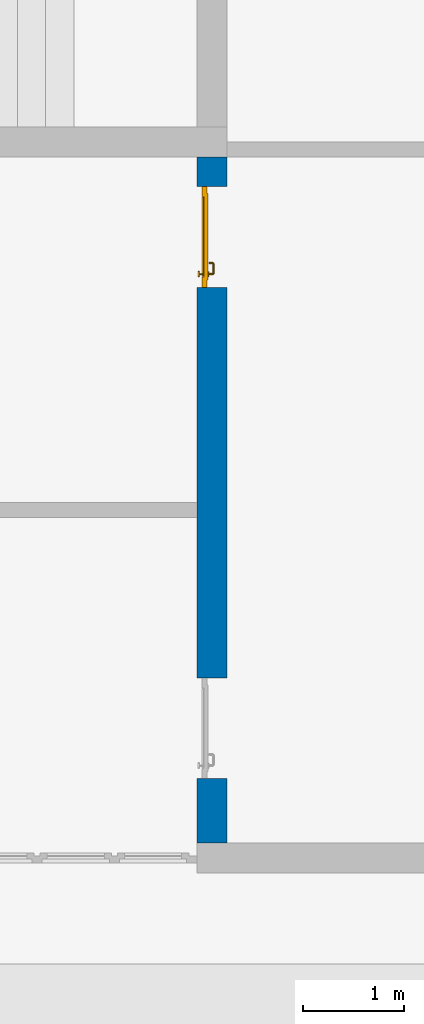
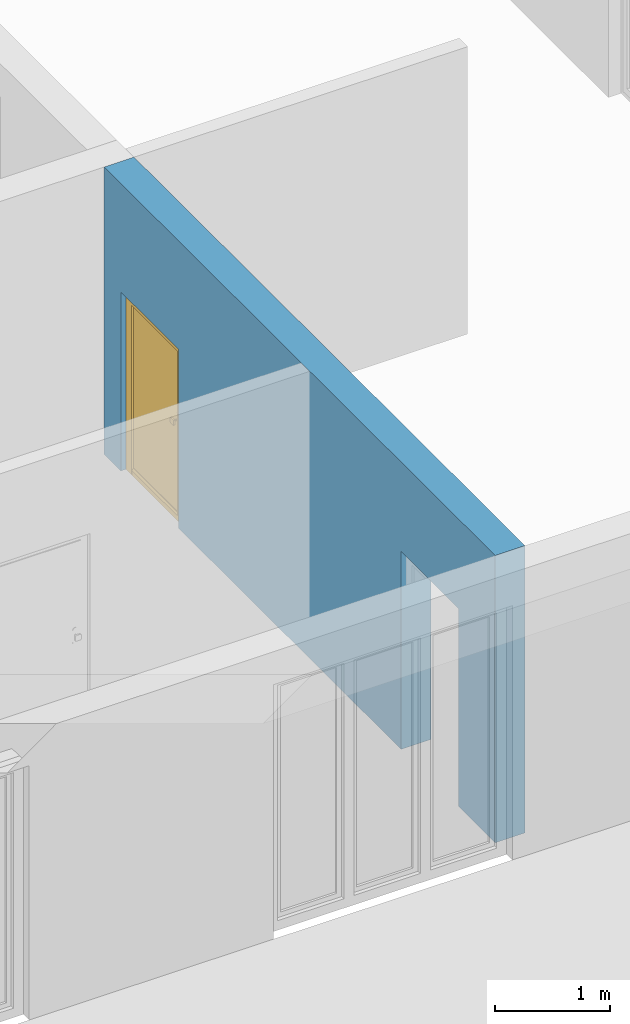
# One storey, part 7 of 23: 1 door, 1 wall, 2 openings.
"""IFC4 building model written with IfcOpenShell, lengths in metres."""

from ifc_helpers import new_model, entity, si_unit, converted_unit, derived_unit, direction, frame, origin_with_axes, place, context, subcontext, project, spatial, polygons, material, type_object, element, fill, save


model = new_model("IFC4")

# Units and contexts
model_context = context("Model", 3, precision=1e-05, world=origin_with_axes(), true_north=direction((0.0, 1.0)))
body_context = subcontext(model_context, "Body", "Model", "MODEL_VIEW")
ifc_project = project(units=[si_unit("LENGTHUNIT", "METRE"), si_unit("AREAUNIT", "SQUARE_METRE"), si_unit("VOLUMEUNIT", "CUBIC_METRE"), converted_unit("PLANEANGLEUNIT", "DEGREE", entity("IfcPlaneAngleMeasure", 0.0174532925199), si_unit("PLANEANGLEUNIT", "RADIAN"), dimensions=[0, 0, 0, 0, 0, 0, 0]), converted_unit("TIMEUNIT", "Year", entity("IfcTimeMeasure", 31556926.0), si_unit("TIMEUNIT", "SECOND"), dimensions=[0, 0, 1, 0, 0, 0, 0]), si_unit("MASSUNIT", "GRAM", prefix="KILO"), si_unit("THERMODYNAMICTEMPERATUREUNIT", "DEGREE_CELSIUS"), si_unit("LUMINOUSINTENSITYUNIT", "LUMEN"), si_unit("ENERGYUNIT", "JOULE", prefix="MEGA"), derived_unit("THERMALCONDUCTANCEUNIT", [(si_unit("POWERUNIT", "WATT"), 1), (si_unit("LENGTHUNIT", "METRE"), -1), (si_unit("THERMODYNAMICTEMPERATUREUNIT", "KELVIN"), -1)]), derived_unit("SPECIFICHEATCAPACITYUNIT", [(si_unit("ENERGYUNIT", "JOULE"), 1), (si_unit("MASSUNIT", "GRAM", prefix="KILO"), -1), (si_unit("THERMODYNAMICTEMPERATUREUNIT", "KELVIN"), -1)]), derived_unit("MASSDENSITYUNIT", [(si_unit("MASSUNIT", "GRAM", prefix="KILO"), 1), (si_unit("VOLUMEUNIT", "CUBIC_METRE"), -1)])], contexts=[model_context])

# Site, building, storey
site_placement = place(None, origin_with_axes())
site = spatial("IfcSite", under=ifc_project, at=site_placement, CompositionType="ELEMENT")
building_placement = place(site_placement, origin_with_axes())
building = spatial("IfcBuilding", under=site, at=building_placement, CompositionType="ELEMENT")
storey_placement = place(building_placement, origin_with_axes())
storey = spatial("IfcBuildingStorey", under=building, at=storey_placement, Name="0. Geschoss", CompositionType="ELEMENT", Elevation=0.0)

# Wall, openings, door
ifc_material = material()
wall_type = type_object("IfcWallType", Name="300", PredefinedType="NOTDEFINED")
wall_placement = place(storey_placement, frame((2.6878006196, -2.52881223104, 0.0), z_axis=(0.0, 0.0, 1.0), x_axis=(0.0, -1.0, 0.0)))
wall = element("IfcWall", 1, at=wall_placement, inside=storey, type_object=wall_type, material=ifc_material, Name="Wand-001", PredefinedType="NOTDEFINED", context=body_context, shape_type="Tessellation", body=[
    polygons([(6.46366655835, 0.15, 0.0), (6.46366655835, 0.15, 2.1), (5.46366655835, 0.15, 2.1), (5.46366655835, 0.15, 0.0), (1.59031106762, 0.15, 0.0), (1.59031106762, 0.15, 1.9), (0.590311067622, 0.15, 1.9), (0.590311067622, 0.15, 0.0), (0.3, 0.15, 0.0), (0.3, 0.15, 3.05), (7.1, 0.15, 3.05), (7.1, 0.15, 0.0), (6.46366655835, -0.1, 0.0), (6.46366655835, -0.15, 0.0), (6.46366655835, -0.15, 2.1), (5.46366655835, -0.15, 2.1), (5.46366655835, -0.1, 0.0), (5.46366655835, -0.15, 0.0), (1.59031106762, -0.15, 0.0), (1.59031106762, -0.15, 1.9), (0.590311067622, -0.15, 1.9), (0.590311067622, -0.15, 0.0), (0.3, -0.15, 0.0), (0.3, -0.15, 3.05), (7.1, -0.15, 3.05), (7.1, -0.15, 0.0)], [[[1, 2, 3, 4, 5, 6, 7, 8, 9, 10, 11, 12]], [[2, 1, 13, 14, 15]], [[3, 2, 15, 16]], [[17, 4, 3, 16, 18]], [[4, 17, 18, 19, 5]], [[19, 20, 6, 5]], [[20, 21, 7, 6]], [[21, 22, 8, 7]], [[23, 9, 8, 22]], [[23, 24, 10, 9]], [[25, 11, 10, 24]], [[12, 11, 25, 26]], [[13, 1, 12, 26, 14]], [[19, 18, 16, 15, 14, 26, 25, 24, 23, 22, 21, 20]]], closed=True),
])
opening_1_placement = place(wall_placement, frame((1.09031106762, 0.0, 0.0), z_axis=(0.0, 0.0, 1.0), x_axis=(1.0, 0.0, 0.0)))
opening_1 = element("IfcOpeningElement", 2, at=opening_1_placement, cuts=wall, context=body_context, identifier="Reference", shape_type="Tessellation", body=[
    polygons([(0.5, -0.1, 0.0), (0.5, -0.1, 1.9), (0.5, -0.151, 1.9), (0.5, -0.151, 0.0), (0.5, 0.151, 0.0), (0.5, 0.151, 1.9), (-0.5, -0.1, 1.9), (-0.5, -0.151, 1.9), (-0.5, 0.151, 1.9), (-0.5, -0.151, 0.0), (-0.5, -0.1, 0.0), (-0.5, 0.151, 0.0)], [[[1, 2, 3, 4]], [[2, 1, 5, 6]], [[7, 8, 3, 2, 6, 9]], [[8, 10, 4, 3]], [[1, 4, 10, 11, 12, 5]], [[6, 5, 12, 9]], [[7, 11, 10, 8]], [[11, 7, 9, 12]]], closed=True),
])
opening_2_placement = place(wall_placement, frame((5.96366655835, 0.0, 0.0), z_axis=(0.0, 0.0, 1.0), x_axis=(1.0, 0.0, 0.0)))
element("IfcOpeningElement", 3, at=opening_2_placement, cuts=wall, context=body_context, identifier="Reference", shape_type="Tessellation", body=[
    polygons([(0.5, -0.1, 0.0), (0.5, -0.1, 2.1), (0.5, -0.151, 2.1), (0.5, -0.151, 0.0), (0.5, 0.151, 0.0), (0.5, 0.151, 2.1), (-0.5, -0.1, 2.1), (-0.5, -0.151, 2.1), (-0.5, 0.151, 2.1), (-0.5, -0.151, 0.0), (-0.5, -0.1, 0.0), (-0.5, 0.151, 0.0)], [[[1, 2, 3, 4]], [[2, 1, 5, 6]], [[7, 8, 3, 2, 6, 9]], [[8, 10, 4, 3]], [[1, 4, 10, 11, 12, 5]], [[6, 5, 12, 9]], [[7, 11, 10, 8]], [[11, 7, 9, 12]]], closed=True),
])
door_type = type_object("IfcDoorType", Name="Eingang 01 1-Fl 26", OperationType="SINGLE_SWING_LEFT", PredefinedType="DOOR")
door_placement = place(opening_1_placement, frame((-0.4, 0.0, 0.0), z_axis=(0.0, 0.0, 1.0), x_axis=(1.0, 0.0, 0.0)))
door = element("IfcDoor", 4, at=door_placement, inside=storey, type_object=door_type, OverallHeight=1.9, OverallWidth=1.0, PredefinedType="DOOR", context=body_context, shape_type="Tessellation", body=[
    polygons([(-0.1, -0.1, 0.0), (-0.1, -0.1, 1.9), (-0.1, -0.08, 1.9), (-0.1, -0.08, 0.0), (0.0, -0.1, 0.0), (0.0, -0.1, 1.8), (0.2699, -0.1, 1.8), (0.3999, -0.1, 1.8), (0.8, -0.1, 1.8), (0.8, -0.1, 0.0), (0.9, -0.1, 0.0), (0.9, -0.1, 1.9), (0.9, -0.08, 1.9), (0.9, -0.08, 0.0), (0.8, -0.08, 0.0), (0.8, -0.08, 1.8), (0.3999, -0.08, 1.8), (0.2699, -0.08, 1.8), (0.0, -0.08, 1.8), (0.0, -0.08, 0.0)], [[[1, 2, 3, 4]], [[1, 5, 6, 7, 8, 9, 10, 11, 12, 2]], [[2, 12, 13, 3]], [[4, 3, 13, 14, 15, 16, 17, 18, 19, 20]], [[5, 1, 4, 20]], [[6, 5, 20, 19]], [[7, 6, 19, 18]], [[8, 7, 18, 17]], [[9, 8, 17, 16]], [[10, 9, 16, 15]], [[11, 10, 15, 14]], [[12, 11, 14, 13]]], closed=True),
    polygons([(-0.1, -0.08, 0.0), (-0.1, -0.08, 1.9), (-0.1, -0.05, 1.9), (-0.1, -0.05, 0.0), (-0.03, -0.08, 0.0), (-0.03, -0.08, 1.83), (0.2999, -0.08, 1.83), (0.3699, -0.08, 1.83), (0.83, -0.08, 1.83), (0.83, -0.08, 0.0), (0.9, -0.08, 0.0), (0.9, -0.08, 1.9), (0.9, -0.05, 1.9), (0.9, -0.05, 0.0), (0.83, -0.05, 0.0), (0.83, -0.05, 1.83), (0.3699, -0.05, 1.83), (0.2999, -0.05, 1.83), (-0.03, -0.05, 1.83), (-0.03, -0.05, 0.0)], [[[1, 2, 3, 4]], [[1, 5, 6, 7, 8, 9, 10, 11, 12, 2]], [[2, 12, 13, 3]], [[4, 3, 13, 14, 15, 16, 17, 18, 19, 20]], [[5, 1, 4, 20]], [[6, 5, 20, 19]], [[7, 6, 19, 18]], [[8, 7, 18, 17]], [[9, 8, 17, 16]], [[10, 9, 16, 15]], [[11, 10, 15, 14]], [[12, 11, 14, 13]]], closed=True),
    polygons([(-0.03, -0.04, 0.0), (-0.03, -0.04, 1.83), (0.83, -0.04, 1.83), (0.83, -0.04, 0.0), (-0.03, -0.08, 0.0), (-0.03, -0.08, 1.83), (0.83, -0.08, 1.83), (0.83, -0.08, 0.0)], [[[1, 2, 3, 4]], [[1, 5, 6, 2]], [[2, 6, 7, 3]], [[3, 7, 8, 4]], [[4, 8, 5, 1]], [[8, 7, 6, 5]]], closed=True),
    polygons([(0.005, -0.1, 0.0), (0.795, -0.1, 0.0), (0.795, -0.1, 0.05), (0.005, -0.1, 0.05), (0.005, -0.08, 0.0), (0.795, -0.08, 0.0), (0.795, -0.08, 0.07), (0.795, -0.085, 0.07), (0.005, -0.085, 0.07), (0.005, -0.08, 0.07)], [[[1, 2, 3, 4]], [[5, 6, 2, 1]], [[2, 6, 7, 8, 3]], [[4, 3, 8, 9]], [[1, 4, 9, 10, 5]], [[10, 7, 6, 5]], [[9, 8, 7, 10]]], closed=True),
    polygons([(0.7835, -0.03, 1.0733826859), (0.77, -0.03, 1.077), (0.77, -0.0301, 1.077), (0.7835, -0.0301, 1.0733826859), (0.793382685902, -0.03, 1.0635), (0.797, -0.03, 1.05), (0.793382685902, -0.03, 1.0365), (0.7835, -0.03, 1.0266173141), (0.77, -0.03, 1.023), (0.7565, -0.03, 1.0266173141), (0.746617314098, -0.03, 1.0365), (0.743, -0.03, 1.05), (0.746617314098, -0.03, 1.0635), (0.7565, -0.03, 1.0733826859), (0.7565, -0.0301, 1.0733826859), (0.77, -0.0399, 1.077), (0.7835, -0.0399, 1.0733826859), (0.793382685902, -0.0301, 1.0635), (0.797, -0.0301, 1.05), (0.793382685902, -0.0301, 1.0365), (0.7835, -0.0301, 1.0266173141), (0.77, -0.0301, 1.023), (0.7565, -0.0301, 1.0266173141), (0.746617314098, -0.0301, 1.0365), (0.743, -0.0301, 1.05), (0.746617314098, -0.0301, 1.0635), (0.7565, -0.0399, 1.0733826859), (0.77, -0.04, 1.077), (0.7835, -0.04, 1.0733826859), (0.793382685902, -0.0399, 1.0635), (0.797, -0.0399, 1.05), (0.793382685902, -0.0399, 1.0365), (0.7835, -0.0399, 1.0266173141), (0.77, -0.0399, 1.023), (0.7565, -0.0399, 1.0266173141), (0.746617314098, -0.0399, 1.0365), (0.743, -0.0399, 1.05), (0.746617314098, -0.0399, 1.0635), (0.7565, -0.04, 1.0733826859), (0.746617314098, -0.04, 1.0635), (0.743, -0.04, 1.05), (0.746617314098, -0.04, 1.0365), (0.7565, -0.04, 1.0266173141), (0.77, -0.04, 1.023), (0.7835, -0.04, 1.0266173141), (0.793382685902, -0.04, 1.0365), (0.797, -0.04, 1.05), (0.793382685902, -0.04, 1.0635)], [[[1, 2, 3, 4]], [[2, 1, 5, 6, 7, 8, 9, 10, 11, 12, 13, 14]], [[2, 14, 15, 3]], [[4, 3, 16, 17]], [[5, 1, 4, 18]], [[6, 5, 18, 19]], [[7, 6, 19, 20]], [[8, 7, 20, 21]], [[9, 8, 21, 22]], [[10, 9, 22, 23]], [[11, 10, 23, 24]], [[12, 11, 24, 25]], [[13, 12, 25, 26]], [[14, 13, 26, 15]], [[3, 15, 27, 16]], [[17, 16, 28, 29]], [[18, 4, 17, 30]], [[19, 18, 30, 31]], [[20, 19, 31, 32]], [[21, 20, 32, 33]], [[22, 21, 33, 34]], [[23, 22, 34, 35]], [[24, 23, 35, 36]], [[25, 24, 36, 37]], [[26, 25, 37, 38]], [[15, 26, 38, 27]], [[16, 27, 39, 28]], [[28, 39, 40, 41, 42, 43, 44, 45, 46, 47, 48, 29]], [[30, 17, 29, 48]], [[31, 30, 48, 47]], [[32, 31, 47, 46]], [[33, 32, 46, 45]], [[34, 33, 45, 44]], [[35, 34, 44, 43]], [[36, 35, 43, 42]], [[37, 36, 42, 41]], [[38, 37, 41, 40]], [[27, 38, 40, 39]]], closed=True),
    polygons([(0.762532169224, -0.031, 0.959692280177), (0.763279754556, -0.031, 0.961639806549), (0.75705, -0.031, 0.972430057958), (0.747569942042, -0.031, 0.96295), (0.765, -0.031, 0.952886751346), (0.765, -0.031, 0.9544), (0.762532169224, -0.03, 0.959692280177), (0.763279754556, -0.03, 0.961639806549), (0.764624817685, -0.03, 0.965143815798), (0.764624817685, -0.031, 0.965143815798), (0.77, -0.031, 0.967425445323), (0.77, -0.031, 0.9759), (0.757, -0.031, 0.972516660498), (0.747483339502, -0.031, 0.963), (0.765, -0.031, 0.95), (0.7441, -0.031, 0.95), (0.765, -0.031, 0.947113248654), (0.765, -0.031, 0.941339745962), (0.765, -0.031, 0.9375), (0.765, -0.03, 0.9375), (0.765, -0.03, 0.941339745962), (0.765, -0.03, 0.947113248654), (0.765, -0.03, 0.95), (0.765, -0.03, 0.952886751346), (0.765, -0.03, 0.9544), (0.746703916638, -0.03, 0.96345), (0.75655, -0.03, 0.973296083362), (0.77, -0.03, 0.9769), (0.77, -0.03, 0.967425445323), (0.775375182315, -0.031, 0.965143815798), (0.776720245444, -0.031, 0.961639806549), (0.78295, -0.031, 0.972430057958), (0.77, -0.031, 0.976), (0.757, -0.0311, 0.972516660498), (0.747483339502, -0.0311, 0.963), (0.744, -0.031, 0.95), (0.747569942042, -0.031, 0.93705), (0.75705, -0.031, 0.927569942042), (0.77, -0.031, 0.9241), (0.77, -0.031, 0.9325), (0.766464466094, -0.031, 0.933964466094), (0.766464466094, -0.03, 0.933964466094), (0.77, -0.03, 0.9231), (0.75655, -0.03, 0.926703916638), (0.77, -0.03, 0.9325), (0.746703916638, -0.03, 0.93655), (0.7431, -0.03, 0.95), (0.746617314098, -0.03, 0.9635), (0.7565, -0.03, 0.973382685902), (0.77, -0.03, 0.977), (0.775375182315, -0.03, 0.965143815798), (0.78345, -0.03, 0.973296083362), (0.776720245444, -0.03, 0.961639806549), (0.777467830776, -0.03, 0.959692280177), (0.777467830776, -0.031, 0.959692280177), (0.775, -0.031, 0.9544), (0.775, -0.031, 0.952886751346), (0.792430057958, -0.031, 0.96295), (0.783, -0.031, 0.972516660498), (0.77, -0.0311, 0.976), (0.757, -0.0399, 0.972516660498), (0.747483339502, -0.0399, 0.963), (0.744, -0.0311, 0.95), (0.747483339502, -0.031, 0.937), (0.757, -0.031, 0.927483339502), (0.77, -0.031, 0.924), (0.78295, -0.031, 0.927569942042), (0.775, -0.031, 0.941339745962), (0.775, -0.031, 0.9375), (0.773535533906, -0.031, 0.933964466094), (0.77, -0.03, 0.923), (0.7565, -0.03, 0.926617314098), (0.78345, -0.03, 0.926703916638), (0.773535533906, -0.03, 0.933964466094), (0.775, -0.03, 0.9375), (0.775, -0.03, 0.941339745962), (0.746617314098, -0.03, 0.9365), (0.743, -0.03, 0.95), (0.746617314098, -0.0301, 0.9635), (0.7565, -0.0301, 0.973382685902), (0.77, -0.0301, 0.977), (0.7835, -0.03, 0.973382685902), (0.793296083362, -0.03, 0.96345), (0.775, -0.03, 0.952886751346), (0.775, -0.03, 0.9544), (0.775, -0.03, 0.95), (0.775, -0.03, 0.947113248654), (0.775, -0.031, 0.947113248654), (0.775, -0.031, 0.95), (0.7959, -0.031, 0.95), (0.792516660498, -0.031, 0.963), (0.783, -0.0311, 0.972516660498), (0.77, -0.0399, 0.976), (0.757, -0.04, 0.972516660498), (0.747483339502, -0.04, 0.963), (0.744, -0.0399, 0.95), (0.747483339502, -0.0311, 0.937), (0.757, -0.0311, 0.927483339502), (0.77, -0.0311, 0.924), (0.783, -0.031, 0.927483339502), (0.792430057958, -0.031, 0.93705), (0.77, -0.0301, 0.923), (0.7565, -0.0301, 0.926617314098), (0.7835, -0.03, 0.926617314098), (0.793296083362, -0.03, 0.93655), (0.746617314098, -0.0301, 0.9365), (0.743, -0.0301, 0.95), (0.746617314098, -0.0399, 0.9635), (0.7565, -0.0399, 0.973382685902), (0.77, -0.0399, 0.977), (0.7835, -0.0301, 0.973382685902), (0.793382685902, -0.03, 0.9635), (0.7969, -0.03, 0.95), (0.796, -0.031, 0.95), (0.792516660498, -0.0311, 0.963), (0.783, -0.0399, 0.972516660498), (0.77, -0.04, 0.976), (0.75695, -0.04, 0.972603263039), (0.747396736961, -0.04, 0.96305), (0.744, -0.04, 0.95), (0.747483339502, -0.0399, 0.937), (0.757, -0.0399, 0.927483339502), (0.77, -0.0399, 0.924), (0.783, -0.0311, 0.927483339502), (0.792516660498, -0.031, 0.937), (0.77, -0.0399, 0.923), (0.7565, -0.0399, 0.926617314098), (0.7835, -0.0301, 0.926617314098), (0.793382685902, -0.03, 0.9365), (0.746617314098, -0.0399, 0.9365), (0.743, -0.0399, 0.95), (0.746617314098, -0.04, 0.9635), (0.7565, -0.04, 0.973382685902), (0.77, -0.04, 0.977), (0.7835, -0.0399, 0.973382685902), (0.793382685902, -0.0301, 0.9635), (0.797, -0.03, 0.95), (0.796, -0.0311, 0.95), (0.792516660498, -0.0399, 0.963), (0.783, -0.04, 0.972516660498), (0.77, -0.04, 0.9761), (0.75655, -0.04, 0.973296083362), (0.746703916638, -0.04, 0.96345), (0.7439, -0.04, 0.95), (0.747483339502, -0.04, 0.937), (0.757, -0.04, 0.927483339502), (0.77, -0.04, 0.924), (0.783, -0.0399, 0.927483339502), (0.792516660498, -0.0311, 0.937), (0.77, -0.04, 0.923), (0.7565, -0.04, 0.926617314098), (0.7835, -0.0399, 0.926617314098), (0.793382685902, -0.0301, 0.9365), (0.746617314098, -0.04, 0.9365), (0.743, -0.04, 0.95), (0.77, -0.04, 0.9769), (0.7835, -0.04, 0.973382685902), (0.793382685902, -0.0399, 0.9635), (0.797, -0.0301, 0.95), (0.796, -0.0399, 0.95), (0.792516660498, -0.04, 0.963), (0.78305, -0.04, 0.972603263039), (0.7431, -0.04, 0.95), (0.747396736961, -0.04, 0.93695), (0.75695, -0.04, 0.927396736961), (0.77, -0.04, 0.9239), (0.783, -0.04, 0.927483339502), (0.792516660498, -0.0399, 0.937), (0.77, -0.04, 0.9231), (0.75655, -0.04, 0.926703916638), (0.7835, -0.04, 0.926617314098), (0.793382685902, -0.0399, 0.9365), (0.746703916638, -0.04, 0.93655), (0.78345, -0.04, 0.973296083362), (0.793382685902, -0.04, 0.9635), (0.797, -0.0399, 0.95), (0.796, -0.04, 0.95), (0.792603263039, -0.04, 0.96305), (0.78305, -0.04, 0.927396736961), (0.792516660498, -0.04, 0.937), (0.78345, -0.04, 0.926703916638), (0.793382685902, -0.04, 0.9365), (0.793296083362, -0.04, 0.96345), (0.797, -0.04, 0.95), (0.7961, -0.04, 0.95), (0.792603263039, -0.04, 0.93695), (0.793296083362, -0.04, 0.93655), (0.7969, -0.04, 0.95)], [[[1, 2, 3, 4, 5, 6]], [[1, 7, 8, 9, 10, 2]], [[10, 11, 12, 3, 2]], [[4, 3, 13, 14]], [[15, 5, 4, 16]], [[6, 5, 15, 17, 18, 19, 20, 21, 22, 23, 24, 25]], [[6, 25, 7, 1]], [[7, 25, 24, 26, 27, 8]], [[9, 8, 27, 28, 29]], [[10, 9, 29, 11]], [[30, 31, 32, 12, 11]], [[3, 12, 33, 13]], [[14, 13, 34, 35]], [[16, 4, 14, 36]], [[17, 15, 16, 37]], [[18, 17, 37, 38]], [[38, 39, 40, 41, 19, 18]], [[19, 41, 42, 20]], [[43, 44, 21, 20, 42, 45]], [[22, 21, 44, 46]], [[23, 22, 46, 47]], [[24, 23, 47, 26]], [[48, 49, 27, 26]], [[49, 50, 28, 27]], [[51, 29, 28, 52, 53]], [[11, 29, 51, 30]], [[30, 51, 53, 54, 55, 31]], [[55, 56, 57, 58, 32, 31]], [[12, 32, 59, 33]], [[13, 33, 60, 34]], [[35, 34, 61, 62]], [[36, 14, 35, 63]], [[37, 16, 36, 64]], [[38, 37, 64, 65]], [[39, 38, 65, 66]], [[39, 67, 68, 69, 70, 40]], [[41, 40, 45, 42]], [[71, 72, 44, 43]], [[73, 43, 45, 74, 75, 76]], [[72, 77, 46, 44]], [[77, 78, 47, 46]], [[78, 48, 26, 47]], [[79, 80, 49, 48]], [[80, 81, 50, 49]], [[50, 82, 52, 28]], [[54, 53, 52, 83, 84, 85]], [[55, 54, 85, 56]], [[85, 84, 86, 87, 76, 75, 69, 68, 88, 89, 57, 56]], [[57, 89, 90, 58]], [[32, 58, 91, 59]], [[33, 59, 92, 60]], [[34, 60, 93, 61]], [[62, 61, 94, 95]], [[63, 35, 62, 96]], [[64, 36, 63, 97]], [[65, 64, 97, 98]], [[66, 65, 98, 99]], [[67, 39, 66, 100]], [[88, 68, 67, 101]], [[70, 69, 75, 74]], [[40, 70, 74, 45]], [[102, 103, 72, 71]], [[104, 71, 43, 73]], [[76, 87, 105, 73]], [[103, 106, 77, 72]], [[106, 107, 78, 77]], [[107, 79, 48, 78]], [[108, 109, 80, 79]], [[109, 110, 81, 80]], [[81, 111, 82, 50]], [[82, 112, 83, 52]], [[86, 84, 83, 113]], [[87, 86, 113, 105]], [[89, 88, 101, 90]], [[58, 90, 114, 91]], [[59, 91, 115, 92]], [[60, 92, 116, 93]], [[61, 93, 117, 94]], [[95, 94, 118, 119]], [[96, 62, 95, 120]], [[97, 63, 96, 121]], [[98, 97, 121, 122]], [[99, 98, 122, 123]], [[100, 66, 99, 124]], [[101, 67, 100, 125]], [[126, 127, 103, 102]], [[128, 102, 71, 104]], [[129, 104, 73, 105]], [[127, 130, 106, 103]], [[130, 131, 107, 106]], [[131, 108, 79, 107]], [[132, 133, 109, 108]], [[133, 134, 110, 109]], [[110, 135, 111, 81]], [[111, 136, 112, 82]], [[112, 137, 113, 83]], [[137, 129, 105, 113]], [[90, 101, 125, 114]], [[91, 114, 138, 115]], [[92, 115, 139, 116]], [[93, 116, 140, 117]], [[94, 117, 141, 118]], [[119, 118, 142, 143]], [[120, 95, 119, 144]], [[121, 96, 120, 145]], [[122, 121, 145, 146]], [[123, 122, 146, 147]], [[124, 99, 123, 148]], [[125, 100, 124, 149]], [[150, 151, 127, 126]], [[152, 126, 102, 128]], [[153, 128, 104, 129]], [[151, 154, 130, 127]], [[154, 155, 131, 130]], [[155, 132, 108, 131]], [[143, 142, 133, 132]], [[142, 156, 134, 133]], [[134, 157, 135, 110]], [[135, 158, 136, 111]], [[136, 159, 137, 112]], [[159, 153, 129, 137]], [[114, 125, 149, 138]], [[115, 138, 160, 139]], [[116, 139, 161, 140]], [[117, 140, 162, 141]], [[118, 141, 156, 142]], [[144, 119, 143, 163]], [[145, 120, 144, 164]], [[146, 145, 164, 165]], [[147, 146, 165, 166]], [[148, 123, 147, 167]], [[149, 124, 148, 168]], [[169, 170, 151, 150]], [[171, 150, 126, 152]], [[172, 152, 128, 153]], [[170, 173, 154, 151]], [[173, 163, 155, 154]], [[163, 143, 132, 155]], [[156, 174, 157, 134]], [[157, 175, 158, 135]], [[158, 176, 159, 136]], [[176, 172, 153, 159]], [[138, 149, 168, 160]], [[139, 160, 177, 161]], [[140, 161, 178, 162]], [[141, 162, 174, 156]], [[164, 144, 163, 173]], [[165, 164, 173, 170]], [[166, 165, 170, 169]], [[167, 147, 166, 179]], [[168, 148, 167, 180]], [[181, 169, 150, 171]], [[182, 171, 152, 172]], [[174, 183, 175, 157]], [[175, 184, 176, 158]], [[184, 182, 172, 176]], [[160, 168, 180, 177]], [[161, 177, 185, 178]], [[162, 178, 183, 174]], [[179, 166, 169, 181]], [[180, 167, 179, 186]], [[187, 181, 171, 182]], [[183, 188, 184, 175]], [[188, 187, 182, 184]], [[177, 180, 186, 185]], [[178, 185, 188, 183]], [[186, 179, 181, 187]], [[185, 186, 187, 188]]], closed=True),
    polygons([(0.78, -0.03, 1.05), (0.777071067812, -0.03, 1.04292893219), (0.777071067812, 0.000696439392025, 1.04292893219), (0.78, 0.000984914033572, 1.05), (0.77, -0.03, 1.04), (0.77, 0.0, 1.04), (0.775518993221, 0.00849924527831, 1.04292893219), (0.778277987014, 0.0096420579258, 1.05), (0.777071067812, -0.03, 1.05707106781), (0.777071067812, 0.000696439392025, 1.05707106781), (0.762928932188, -0.03, 1.04292893219), (0.762928932188, -0.000696439392024, 1.04292893219), (0.768858192988, 0.00574025148548, 1.04), (0.770704557509, 0.0157045575088, 1.04292893219), (0.772816199938, 0.0178161999379, 1.05), (0.775518993221, 0.00849924527831, 1.05707106781), (0.77, -0.03, 1.06), (0.77, 0.0, 1.06), (0.76, -0.03, 1.05), (0.76, -0.000984914033571, 1.05), (0.762197392755, 0.00298125769265, 1.04292893219), (0.765606601718, 0.0106066017178, 1.04), (0.763499245278, 0.0205189932208, 1.04292893219), (0.764642057926, 0.0232779870137, 1.05), (0.770704557509, 0.0157045575088, 1.05707106781), (0.768858192988, 0.00574025148548, 1.06), (0.762928932188, -0.03, 1.05707106781), (0.762928932188, -0.000696439392024, 1.05707106781), (0.759438398962, 0.00183844504515, 1.05), (0.760508645927, 0.00550864592676, 1.04292893219), (0.760740251485, 0.0138581929877, 1.04), (0.755696439392, 0.0220710678119, 1.04292893219), (0.755984914034, 0.025, 1.05), (0.763499245278, 0.0205189932208, 1.05707106781), (0.765606601718, 0.0106066017178, 1.06), (0.762197392755, 0.00298125769265, 1.05707106781), (0.758397003498, 0.00339700349773, 1.05), (0.757981257693, 0.00719739275452, 1.04292893219), (0.755, 0.015, 1.04), (0.674303560608, 0.0220710678119, 1.04292893219), (0.674015085966, 0.025, 1.05), (0.755696439392, 0.0220710678119, 1.05707106781), (0.760740251485, 0.0138581929877, 1.06), (0.760508645927, 0.00550864592676, 1.05707106781), (0.756838445045, 0.00443839896169, 1.05), (0.754303560608, 0.00792893218813, 1.04292893219), (0.675, 0.015, 1.04), (0.666500754722, 0.0205189932208, 1.04292893219), (0.665357942074, 0.0232779870137, 1.05), (0.674303560608, 0.0220710678119, 1.05707106781), (0.755, 0.015, 1.06), (0.757981257693, 0.00719739275452, 1.05707106781), (0.754015085966, 0.005, 1.05), (0.675696439392, 0.00792893218813, 1.04292893219), (0.669259748515, 0.0138581929877, 1.04), (0.659295442491, 0.0157045575088, 1.04292893219), (0.657183800062, 0.0178161999379, 1.05), (0.666500754722, 0.0205189932208, 1.05707106781), (0.675, 0.015, 1.06), (0.754303560608, 0.00792893218813, 1.05707106781), (0.675984914034, 0.005, 1.05), (0.672018742307, 0.00719739275452, 1.04292893219), (0.664393398282, 0.0106066017178, 1.04), (0.654481006779, 0.00849924527831, 1.04292893219), (0.651722012986, 0.0096420579258, 1.05), (0.659295442491, 0.0157045575088, 1.05707106781), (0.669259748515, 0.0138581929877, 1.06), (0.675696439392, 0.00792893218813, 1.05707106781), (0.673161554955, 0.00443839896169, 1.05), (0.669491354073, 0.00550864592676, 1.04292893219), (0.661141807012, 0.00574025148548, 1.04), (0.652928932188, 0.000696439392025, 1.04292893219), (0.65, 0.000984914033572, 1.05), (0.654481006779, 0.00849924527831, 1.05707106781), (0.664393398282, 0.0106066017178, 1.06), (0.672018742307, 0.00719739275452, 1.05707106781), (0.671602996502, 0.00339700349773, 1.05), (0.667802607245, 0.00298125769265, 1.04292893219), (0.66, 0.0, 1.04), (0.652928932188, -0.03, 1.04292893219), (0.65, -0.03, 1.05), (0.652928932188, 0.000696439392025, 1.05707106781), (0.661141807012, 0.00574025148548, 1.06), (0.669491354073, 0.00550864592676, 1.05707106781), (0.670561601038, 0.00183844504515, 1.05), (0.667071067812, -0.000696439392024, 1.04292893219), (0.66, -0.03, 1.04), (0.667071067812, -0.03, 1.04292893219), (0.67, -0.03, 1.05), (0.667071067812, -0.03, 1.05707106781), (0.66, -0.03, 1.06), (0.652928932188, -0.03, 1.05707106781), (0.66, 0.0, 1.06), (0.667802607245, 0.00298125769265, 1.05707106781), (0.67, -0.000984914033571, 1.05), (0.667071067812, -0.000696439392024, 1.05707106781)], [[[1, 2, 3, 4]], [[2, 5, 6, 3]], [[4, 3, 7, 8]], [[9, 1, 4, 10]], [[5, 11, 12, 6]], [[3, 6, 13, 7]], [[8, 7, 14, 15]], [[10, 4, 8, 16]], [[17, 9, 10, 18]], [[11, 19, 20, 12]], [[6, 12, 21, 13]], [[7, 13, 22, 14]], [[15, 14, 23, 24]], [[16, 8, 15, 25]], [[18, 10, 16, 26]], [[27, 17, 18, 28]], [[19, 27, 28, 20]], [[12, 20, 29, 21]], [[13, 21, 30, 22]], [[14, 22, 31, 23]], [[24, 23, 32, 33]], [[25, 15, 24, 34]], [[26, 16, 25, 35]], [[28, 18, 26, 36]], [[20, 28, 36, 29]], [[21, 29, 37, 30]], [[22, 30, 38, 31]], [[23, 31, 39, 32]], [[33, 32, 40, 41]], [[34, 24, 33, 42]], [[35, 25, 34, 43]], [[36, 26, 35, 44]], [[29, 36, 44, 37]], [[30, 37, 45, 38]], [[31, 38, 46, 39]], [[32, 39, 47, 40]], [[41, 40, 48, 49]], [[42, 33, 41, 50]], [[43, 34, 42, 51]], [[44, 35, 43, 52]], [[37, 44, 52, 45]], [[38, 45, 53, 46]], [[39, 46, 54, 47]], [[40, 47, 55, 48]], [[49, 48, 56, 57]], [[50, 41, 49, 58]], [[51, 42, 50, 59]], [[52, 43, 51, 60]], [[45, 52, 60, 53]], [[46, 53, 61, 54]], [[47, 54, 62, 55]], [[48, 55, 63, 56]], [[57, 56, 64, 65]], [[58, 49, 57, 66]], [[59, 50, 58, 67]], [[60, 51, 59, 68]], [[53, 60, 68, 61]], [[54, 61, 69, 62]], [[55, 62, 70, 63]], [[56, 63, 71, 64]], [[65, 64, 72, 73]], [[66, 57, 65, 74]], [[67, 58, 66, 75]], [[68, 59, 67, 76]], [[61, 68, 76, 69]], [[62, 69, 77, 70]], [[63, 70, 78, 71]], [[64, 71, 79, 72]], [[73, 72, 80, 81]], [[74, 65, 73, 82]], [[75, 66, 74, 83]], [[76, 67, 75, 84]], [[69, 76, 84, 77]], [[70, 77, 85, 78]], [[71, 78, 86, 79]], [[72, 79, 87, 80]], [[81, 80, 87, 88, 89, 90, 91, 92]], [[82, 73, 81, 92]], [[83, 74, 82, 93]], [[84, 75, 83, 94]], [[77, 84, 94, 85]], [[78, 85, 95, 86]], [[79, 86, 88, 87]], [[86, 95, 89, 88]], [[95, 96, 90, 89]], [[96, 93, 91, 90]], [[93, 82, 92, 91]], [[94, 83, 93, 96]], [[85, 94, 96, 95]]], closed=False),
    polygons([(0.764696699141, -0.085, 1.04469669914), (0.7625, -0.085, 1.05), (0.764696699141, -0.085, 1.05530330086), (0.77, -0.085, 1.0575), (0.775303300859, -0.085, 1.05530330086), (0.7775, -0.085, 1.05), (0.775303300859, -0.085, 1.04469669914), (0.77, -0.085, 1.0425), (0.764696699141, -0.125, 1.04469669914), (0.7625, -0.125, 1.05), (0.764696699141, -0.125, 1.05530330086), (0.77, -0.125, 1.0575), (0.775303300859, -0.125, 1.05530330086), (0.7775, -0.125, 1.05), (0.775303300859, -0.125, 1.04469669914), (0.77, -0.125, 1.0425)], [[[1, 2, 3, 4, 5, 6, 7, 8]], [[1, 9, 10, 2]], [[2, 10, 11, 3]], [[3, 11, 12, 4]], [[4, 12, 13, 5]], [[5, 13, 14, 6]], [[6, 14, 15, 7]], [[7, 15, 16, 8]], [[8, 16, 9, 1]], [[9, 16, 15, 14, 13, 12, 11, 10]]], closed=True),
    polygons([(0.795, -0.08, 0.975), (0.795, -0.085, 0.975), (0.793096988313, -0.085, 0.965432914191), (0.793096988313, -0.08, 0.965432914191), (0.795, -0.08, 1.1), (0.795, -0.085, 1.1), (0.793096988313, -0.085, 1.10956708581), (0.78767766953, -0.085, 1.11767766953), (0.779567085809, -0.085, 1.12309698831), (0.77, -0.085, 1.125), (0.760432914191, -0.085, 1.12309698831), (0.75232233047, -0.085, 1.11767766953), (0.746903011687, -0.085, 1.10956708581), (0.745, -0.085, 1.1), (0.745, -0.085, 0.975), (0.746903011687, -0.085, 0.965432914191), (0.75232233047, -0.085, 0.95732233047), (0.760432914191, -0.085, 0.951903011687), (0.77, -0.085, 0.95), (0.779567085809, -0.085, 0.951903011687), (0.78767766953, -0.085, 0.95732233047), (0.78767766953, -0.08, 0.95732233047), (0.779567085809, -0.08, 0.951903011687), (0.77, -0.08, 0.95), (0.760432914191, -0.08, 0.951903011687), (0.75232233047, -0.08, 0.95732233047), (0.746903011687, -0.08, 0.965432914191), (0.745, -0.08, 0.975), (0.745, -0.08, 1.1), (0.746903011687, -0.08, 1.10956708581), (0.75232233047, -0.08, 1.11767766953), (0.760432914191, -0.08, 1.12309698831), (0.77, -0.08, 1.125), (0.779567085809, -0.08, 1.12309698831), (0.78767766953, -0.08, 1.11767766953), (0.793096988313, -0.08, 1.10956708581)], [[[1, 2, 3, 4]], [[5, 6, 2, 1]], [[2, 6, 7, 8, 9, 10, 11, 12, 13, 14, 15, 16, 17, 18, 19, 20, 21, 3]], [[4, 3, 21, 22]], [[1, 4, 22, 23, 24, 25, 26, 27, 28, 29, 30, 31, 32, 33, 34, 35, 36, 5]], [[36, 7, 6, 5]], [[35, 8, 7, 36]], [[34, 9, 8, 35]], [[33, 10, 9, 34]], [[32, 11, 10, 33]], [[31, 12, 11, 32]], [[30, 13, 12, 31]], [[29, 14, 13, 30]], [[28, 15, 14, 29]], [[27, 16, 15, 28]], [[26, 17, 16, 27]], [[25, 18, 17, 26]], [[24, 19, 18, 25]], [[23, 20, 19, 24]], [[22, 21, 20, 23]]], closed=True),
    polygons([(0.79, -0.125, 1.08), (0.79, -0.14, 1.08), (0.795, -0.14, 1.07866025404), (0.795, -0.125, 1.07866025404), (0.75, -0.125, 1.08), (0.75, -0.14, 1.08), (0.745, -0.14, 1.07866025404), (0.741339745962, -0.14, 1.075), (0.74, -0.14, 1.07), (0.74, -0.14, 1.03), (0.741339745962, -0.14, 1.025), (0.745, -0.14, 1.02133974596), (0.75, -0.14, 1.02), (0.79, -0.14, 1.02), (0.795, -0.14, 1.02133974596), (0.798660254038, -0.14, 1.025), (0.8, -0.14, 1.03), (0.8, -0.14, 1.07), (0.798660254038, -0.14, 1.075), (0.798660254038, -0.125, 1.075), (0.8, -0.125, 1.07), (0.8, -0.125, 1.03), (0.798660254038, -0.125, 1.025), (0.795, -0.125, 1.02133974596), (0.79, -0.125, 1.02), (0.75, -0.125, 1.02), (0.745, -0.125, 1.02133974596), (0.741339745962, -0.125, 1.025), (0.74, -0.125, 1.03), (0.74, -0.125, 1.07), (0.741339745962, -0.125, 1.075), (0.745, -0.125, 1.07866025404)], [[[1, 2, 3, 4]], [[5, 6, 2, 1]], [[2, 6, 7, 8, 9, 10, 11, 12, 13, 14, 15, 16, 17, 18, 19, 3]], [[4, 3, 19, 20]], [[1, 4, 20, 21, 22, 23, 24, 25, 26, 27, 28, 29, 30, 31, 32, 5]], [[32, 7, 6, 5]], [[31, 8, 7, 32]], [[30, 9, 8, 31]], [[29, 10, 9, 30]], [[28, 11, 10, 29]], [[27, 12, 11, 28]], [[26, 13, 12, 27]], [[25, 14, 13, 26]], [[24, 15, 14, 25]], [[23, 16, 15, 24]], [[22, 17, 16, 23]], [[21, 18, 17, 22]], [[20, 19, 18, 21]]], closed=True),
])
fill(opening_1, door)

save(model, "model.ifc")
